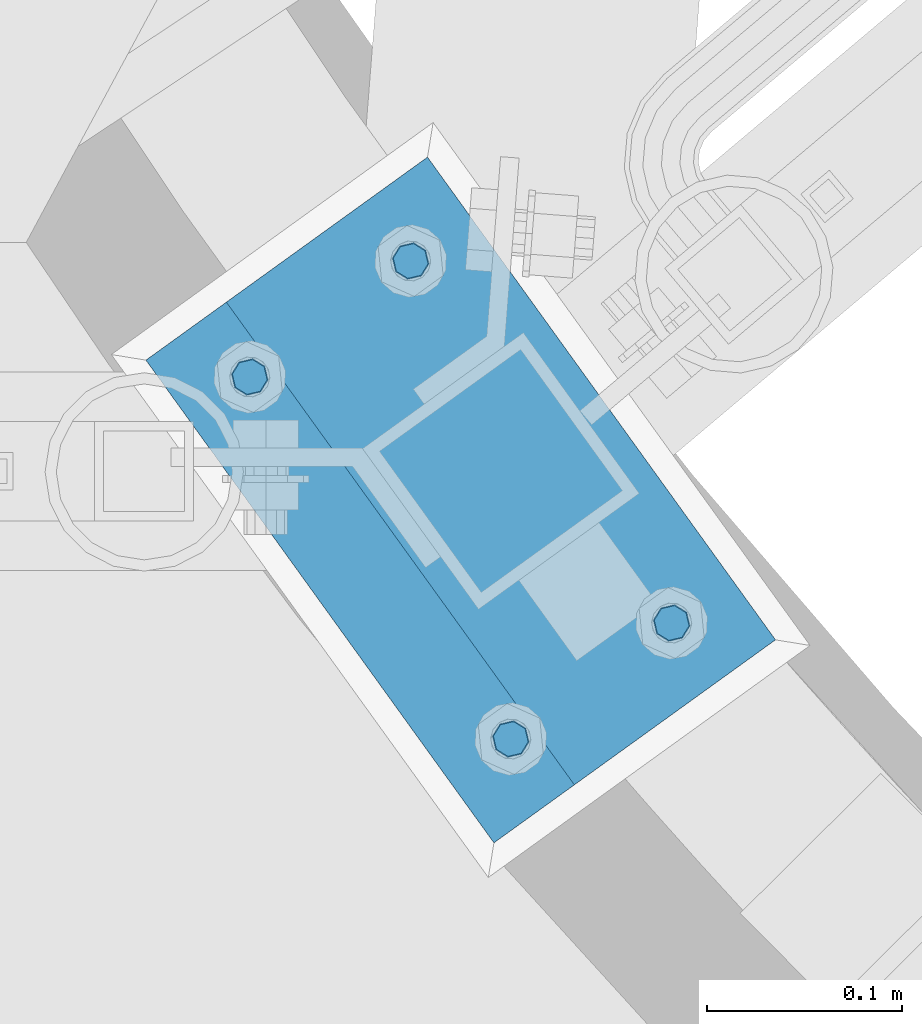
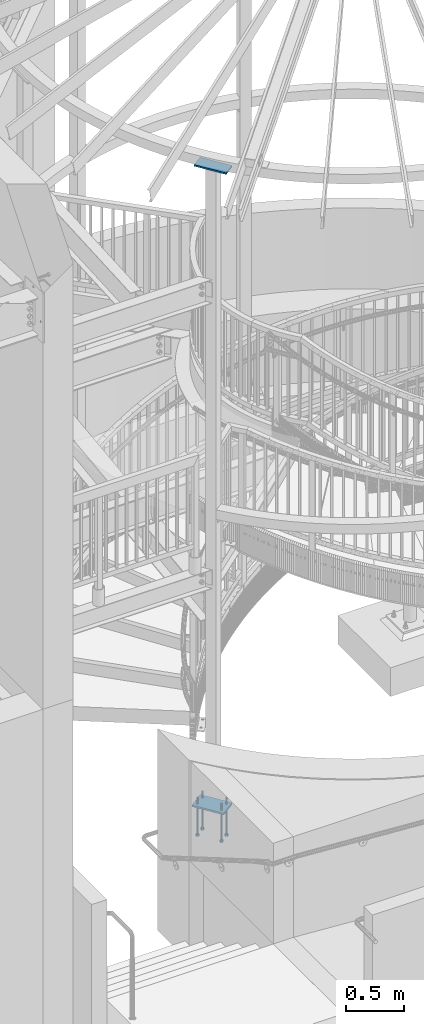
# One storey, part 466 of 975: 7 beams.
"""IFC2X3 building model written with IfcOpenShell, lengths in millimetres."""

from ifc_helpers import new_model, si_unit, frame, origin_with_axes, place, context, subcontext, project, spatial, faceted_brep, material, type_object, element, save


model = new_model("IFC2X3")

# Units and contexts
model_context = context("Model", 3, precision=1e-05, world=origin_with_axes())
body_context = subcontext(model_context, "Body", "Model", "MODEL_VIEW")
ifc_project = project(units=[si_unit("LENGTHUNIT", "METRE", prefix="MILLI"), si_unit("AREAUNIT", "SQUARE_METRE"), si_unit("VOLUMEUNIT", "CUBIC_METRE"), si_unit("MASSUNIT", "GRAM", prefix="KILO"), si_unit("TIMEUNIT", "SECOND"), si_unit("PLANEANGLEUNIT", "RADIAN"), si_unit("SOLIDANGLEUNIT", "STERADIAN"), si_unit("THERMODYNAMICTEMPERATUREUNIT", "DEGREE_CELSIUS"), si_unit("LUMINOUSINTENSITYUNIT", "LUMEN")], contexts=[model_context])

# Site, building, storey
site_placement = place(None, origin_with_axes())
site = spatial("IfcSite", under=ifc_project, at=site_placement, CompositionType="ELEMENT")
building_placement = place(site_placement, origin_with_axes())
building = spatial("IfcBuilding", under=site, at=building_placement, Name="Undefined", CompositionType="ELEMENT")
storey_placement = place(building_placement, origin_with_axes())
storey = spatial("IfcBuildingStorey", under=building, at=storey_placement, Name="Undefined", CompositionType="ELEMENT", Elevation=0.0)

# Beams
ifc_material_1 = material(Name="STEEL/A36")
beam_type_1 = type_object("IfcBeamType", PredefinedType="NOTDEFINED")
beam_1_placement = place(storey_placement, frame((32239.394978559, 1241.42612936098, 8170.86249705359), z_axis=(0.811165211384543, 0.584817065277228, 0.0), x_axis=(-0.584817058957379, 0.811165215940897, 0.0)))
element("IfcBeam", 1, at=beam_1_placement, inside=storey, type_object=beam_type_1, material=ifc_material_1, Name="PLATE", context=body_context, shape_type="Brep", body=[
    faceted_brep([(0.0, 7.9375, -63.5), (0.0, 7.9375, 63.5), (304.799999999529, 7.9375, 63.5), (304.799999999529, 7.9375, -63.5), (0.0, -7.9375, 63.5), (304.799999999529, -7.9375, 63.5), (0.0, -7.9375, -63.5), (304.799999999529, -7.9375, -63.5)], [[[0, 1, 2, 3]], [[1, 4, 5, 2]], [[4, 6, 7, 5]], [[6, 0, 3, 7]], [[5, 7, 3, 2]], [[6, 4, 1, 0]]]),
])
ifc_material_2 = material(Name="STEEL/F1554-36")
beam_type_2 = type_object("IfcBeamType", PredefinedType="NOTDEFINED")
beam_2_placement = place(storey_placement, frame((32021.6134781423, 1413.20083086344, 1371.59999705359), z_axis=(0.584817065277228, -0.811165211384543, 0.0), x_axis=(0.0, 0.0, -1.0)))
element("IfcBeam", 2, at=beam_2_placement, inside=storey, type_object=beam_type_2, material=ifc_material_2, Name="HEADED_ANCHOR_BOLT", context=body_context, shape_type="Brep", body=[
    faceted_brep([(260.34375, -9.13000011445183, 15.8100004195221), (260.34375, -18.2600002289691, -1.45519152283669e-11), (279.393749999999, -18.2600002289691, -1.45519152283669e-11), (279.393749999999, -9.13000011445183, 15.8100004195221), (260.34375, 9.13000011451732, 15.8100004195403), (279.393749999999, 9.13000011451732, 15.8100004195403), (260.34375, 18.2600002289728, 1.81898940354586e-11), (279.393749999999, 18.2600002289728, 1.81898940354586e-11), (260.34375, 9.13000011445547, -15.8100004195221), (279.393749999999, 9.13000011445547, -15.8100004195221), (260.34375, -9.13000011451732, -15.8100004195367), (279.393749999999, -9.13000011451732, -15.8100004195367), (260.34375, -4.47768005528269, 9.29799844174704), (260.34375, -8.06850066050174, 6.43441456486471), (260.34375, -10.0612557562381, 2.29641597050068), (260.34375, -10.0612557562454, -2.29641597051523), (260.34375, -8.06850066052721, -6.43441456487926), (260.34375, -4.47768005531907, -9.29799844175068), (260.34375, -1.81898940354586e-11, -10.319999694766), (260.34375, 4.47768005528633, -9.2979984417434), (260.34375, 8.06850066050174, -6.43441456486471), (260.34375, 10.0612557562381, -2.29641597050068), (260.34375, 10.0612557562454, 2.29641597051886), (260.34375, 8.06850066052357, 6.4344145648829), (260.34375, 4.47768005532271, 9.29799844175432), (260.34375, 2.18278728425503e-11, 10.3199996947696), (279.393749999999, 2.18278728425503e-11, 10.3199996947696), (279.393749999999, -4.47768005528269, 9.29799844174704), (279.393749999999, -8.06850066050174, 6.43441456486471), (279.393749999999, -10.0612557562381, 2.29641597050068), (279.393749999999, -10.0612557562454, -2.29641597051523), (279.393749999999, -8.06850066052721, -6.43441456487926), (279.393749999999, -4.47768005531907, -9.29799844175068), (279.393749999999, -1.81898940354586e-11, -10.319999694766), (279.393749999999, 4.47768005528633, -9.2979984417434), (279.393749999999, 8.06850066050174, -6.43441456486471), (279.393749999999, 10.0612557562381, -2.29641597050068), (279.393749999999, 10.0612557562454, 2.29641597051886), (279.393749999999, 8.06850066052357, 6.4344145648829), (279.393749999999, 4.47768005532271, 9.29799844175432), (0.0, -6.73519209080223, 6.73519209080186), (0.0, -9.52499999999964, 0.0), (279.400000000001, -9.52499999999782, -3.63797880709171e-12), (279.400000000001, -6.73519209079313, 6.73519209079313), (-9.87109982941227e-13, -1.20792265079217e-13, 9.52499961853027), (279.400000000001, 1.09139364212751e-11, 9.52499999999054), (0.0, 6.73519209080223, 6.73519209080186), (279.400000000001, 6.73519209081132, 6.73519209079677), (0.0, 9.52499999999964, 0.0), (279.400000000001, 9.52500000000146, 3.63797880709171e-12), (0.0, 6.73519209080223, -6.73519209080186), (279.400000000001, 6.73519209079677, -6.73519209079313), (2.95075507493764e-12, -1.20792265079217e-13, -9.52499961853027), (279.400000000001, -1.09139364212751e-11, -9.5249999999869), (-126.99791499542, -6.36396103070001, 6.3639610306418), (-126.99791499542, 1.81898940354586e-11, 8.99999999995271), (-126.99791499542, 6.36396103072184, 6.36396103065272), (-126.99791499542, 9.00000000004366, 1.09139364212751e-11), (-126.99791499542, 6.36396103069637, -6.3639610306418), (-126.99791499542, -1.81898940354586e-11, -8.99999999995271), (-126.99791499542, -6.36396103072184, -6.36396103064908), (-126.99791499542, -9.00000000004002, -7.27595761418343e-12), (0.0149743263646087, 6.36396103067818, -6.36396103067909), (0.0149743263646087, 0.0, -9.0), (0.0149743263646087, -6.36396103067818, -6.36396103067909), (0.0149743263987148, -8.9999995411581, -1.00796984270346e-06), (0.0149743263646087, -6.36396103067818, 6.36396103067909), (0.0149743263646087, 0.0, 9.0), (0.0149743263646087, 6.36396103067818, 6.36396103067909), (0.0149743263987148, 9.0000004588419, -1.00796984270346e-06), (0.0, -6.73519209080223, -6.73519209080186), (279.400000000001, -6.73519209080769, -6.73519209079677)], [[[0, 1, 2, 3]], [[4, 0, 3, 5]], [[6, 4, 5, 7]], [[8, 6, 7, 9]], [[10, 8, 9, 11]], [[0, 4, 6, 8, 10, 1], [12, 13, 14, 15, 16, 17, 18, 19, 20, 21, 22, 23, 24, 25]], [[12, 25, 26, 27]], [[13, 12, 27, 28]], [[14, 13, 28, 29]], [[15, 14, 29, 30]], [[16, 15, 30, 31]], [[17, 16, 31, 32]], [[18, 17, 32, 33]], [[19, 18, 33, 34]], [[20, 19, 34, 35]], [[21, 20, 35, 36]], [[22, 21, 36, 37]], [[23, 22, 37, 38]], [[24, 23, 38, 39]], [[25, 24, 39, 26]], [[9, 7, 5, 3, 2, 11], [38, 37, 36, 35, 34, 33, 32, 31, 30, 29, 28, 27, 26, 39]], [[1, 10, 11, 2]], [[40, 41, 42, 43]], [[44, 40, 43, 45]], [[46, 44, 45, 47]], [[48, 46, 47, 49]], [[50, 48, 49, 51]], [[52, 50, 51, 53]], [[54, 55, 56, 57, 58, 59, 60, 61]], [[59, 58, 62, 63]], [[60, 59, 63, 64]], [[61, 60, 64, 65]], [[54, 61, 65, 66]], [[55, 54, 66, 67]], [[56, 55, 67, 68]], [[57, 56, 68, 69]], [[58, 57, 69, 62]], [[40, 44, 46, 48, 50, 52, 70, 41], [68, 67, 66, 65, 64, 63, 62, 69]], [[41, 70, 71, 42]], [[53, 51, 49, 47, 45, 43, 42, 71]], [[70, 52, 53, 71]]]),
])
beam_3_placement = place(storey_placement, frame((32104.0278600483, 1472.6182496472, 1371.59999705359), z_axis=(-0.584817058957379, 0.811165215940897, 0.0), x_axis=(0.0, 0.0, -1.0)))
element("IfcBeam", 3, at=beam_3_placement, inside=storey, type_object=beam_type_2, material=ifc_material_2, Name="HEADED_ANCHOR_BOLT", context=body_context, shape_type="Brep", body=[
    faceted_brep([(260.34375, -9.13000011445183, 15.8100004195221), (260.34375, -18.2600002289691, -1.45519152283669e-11), (279.393749999999, -18.2600002289691, -1.45519152283669e-11), (279.393749999999, -9.13000011445183, 15.8100004195221), (260.34375, 9.13000011451732, 15.8100004195403), (279.393749999999, 9.13000011451732, 15.8100004195403), (260.34375, 18.2600002289728, 1.81898940354586e-11), (279.393749999999, 18.2600002289728, 1.81898940354586e-11), (260.34375, 9.13000011445547, -15.8100004195221), (279.393749999999, 9.13000011445547, -15.8100004195221), (260.34375, -9.13000011451732, -15.8100004195367), (279.393749999999, -9.13000011451732, -15.8100004195367), (260.34375, -4.47768005528269, 9.29799844174704), (260.34375, -8.06850066050174, 6.43441456486471), (260.34375, -10.0612557562381, 2.29641597050068), (260.34375, -10.0612557562454, -2.29641597051523), (260.34375, -8.06850066052721, -6.43441456487926), (260.34375, -4.47768005531907, -9.29799844175068), (260.34375, -1.81898940354586e-11, -10.319999694766), (260.34375, 4.47768005528633, -9.2979984417434), (260.34375, 8.06850066050174, -6.43441456486471), (260.34375, 10.0612557562381, -2.29641597050068), (260.34375, 10.0612557562454, 2.29641597051886), (260.34375, 8.06850066052357, 6.4344145648829), (260.34375, 4.47768005532271, 9.29799844175432), (260.34375, 2.18278728425503e-11, 10.3199996947696), (279.393749999999, 2.18278728425503e-11, 10.3199996947696), (279.393749999999, -4.47768005528269, 9.29799844174704), (279.393749999999, -8.06850066050174, 6.43441456486471), (279.393749999999, -10.0612557562381, 2.29641597050068), (279.393749999999, -10.0612557562454, -2.29641597051523), (279.393749999999, -8.06850066052721, -6.43441456487926), (279.393749999999, -4.47768005531907, -9.29799844175068), (279.393749999999, -1.81898940354586e-11, -10.319999694766), (279.393749999999, 4.47768005528633, -9.2979984417434), (279.393749999999, 8.06850066050174, -6.43441456486471), (279.393749999999, 10.0612557562381, -2.29641597050068), (279.393749999999, 10.0612557562454, 2.29641597051886), (279.393749999999, 8.06850066052357, 6.4344145648829), (279.393749999999, 4.47768005532271, 9.29799844175432), (0.0, -6.73519209080223, 6.73519209080186), (0.0, -9.52499999999964, 0.0), (279.400000000001, -9.52499999999782, -3.63797880709171e-12), (279.400000000001, -6.73519209079313, 6.73519209079313), (-9.87109982941227e-13, -1.20792265079217e-13, 9.52499961853027), (279.400000000001, 1.09139364212751e-11, 9.52499999999054), (0.0, 6.73519209080223, 6.73519209080186), (279.400000000001, 6.73519209081132, 6.73519209079677), (0.0, 9.52499999999964, 0.0), (279.400000000001, 9.52500000000146, 3.63797880709171e-12), (0.0, 6.73519209080223, -6.73519209080186), (279.400000000001, 6.73519209079677, -6.73519209079313), (2.95075507493764e-12, -1.20792265079217e-13, -9.52499961853027), (279.400000000001, -1.09139364212751e-11, -9.5249999999869), (-126.99791499542, -6.36396103070001, 6.3639610306418), (-126.99791499542, 1.81898940354586e-11, 8.99999999995271), (-126.99791499542, 6.36396103072184, 6.36396103065272), (-126.99791499542, 9.00000000004366, 1.09139364212751e-11), (-126.99791499542, 6.36396103069637, -6.3639610306418), (-126.99791499542, -1.81898940354586e-11, -8.99999999995271), (-126.99791499542, -6.36396103072184, -6.36396103064908), (-126.99791499542, -9.00000000004002, -7.27595761418343e-12), (0.0149743263646087, 6.36396103067818, -6.36396103067909), (0.0149743263646087, 0.0, -9.0), (0.0149743263646087, -6.36396103067818, -6.36396103067909), (0.0149743263987148, -8.9999995411581, -1.00796984270346e-06), (0.0149743263646087, -6.36396103067818, 6.36396103067909), (0.0149743263646087, 0.0, 9.0), (0.0149743263646087, 6.36396103067818, 6.36396103067909), (0.0149743263987148, 9.0000004588419, -1.00796984270346e-06), (0.0, -6.73519209080223, -6.73519209080186), (279.400000000001, -6.73519209080769, -6.73519209079677)], [[[0, 1, 2, 3]], [[4, 0, 3, 5]], [[6, 4, 5, 7]], [[8, 6, 7, 9]], [[10, 8, 9, 11]], [[0, 4, 6, 8, 10, 1], [12, 13, 14, 15, 16, 17, 18, 19, 20, 21, 22, 23, 24, 25]], [[12, 25, 26, 27]], [[13, 12, 27, 28]], [[14, 13, 28, 29]], [[15, 14, 29, 30]], [[16, 15, 30, 31]], [[17, 16, 31, 32]], [[18, 17, 32, 33]], [[19, 18, 33, 34]], [[20, 19, 34, 35]], [[21, 20, 35, 36]], [[22, 21, 36, 37]], [[23, 22, 37, 38]], [[24, 23, 38, 39]], [[25, 24, 39, 26]], [[9, 7, 5, 3, 2, 11], [38, 37, 36, 35, 34, 33, 32, 31, 30, 29, 28, 27, 26, 39]], [[1, 10, 11, 2]], [[40, 41, 42, 43]], [[44, 40, 43, 45]], [[46, 44, 45, 47]], [[48, 46, 47, 49]], [[50, 48, 49, 51]], [[52, 50, 51, 53]], [[54, 55, 56, 57, 58, 59, 60, 61]], [[59, 58, 62, 63]], [[60, 59, 63, 64]], [[61, 60, 64, 65]], [[54, 61, 65, 66]], [[55, 54, 66, 67]], [[56, 55, 67, 68]], [[57, 56, 68, 69]], [[58, 57, 69, 62]], [[40, 44, 46, 48, 50, 52, 70, 41], [68, 67, 66, 65, 64, 63, 62, 69]], [[41, 70, 71, 42]], [[53, 51, 49, 47, 45, 43, 42, 71]], [[70, 52, 53, 71]]]),
])
beam_4_placement = place(storey_placement, frame((32237.717041171, 1287.18588232324, 1371.59999705359), z_axis=(-0.584817058957379, 0.811165215940897, 0.0), x_axis=(0.0, 0.0, -1.0)))
element("IfcBeam", 4, at=beam_4_placement, inside=storey, type_object=beam_type_2, material=ifc_material_2, Name="HEADED_ANCHOR_BOLT", context=body_context, shape_type="Brep", body=[
    faceted_brep([(260.34375, -9.13000011445183, 15.8100004195221), (260.34375, -18.2600002289691, -1.45519152283669e-11), (279.393749999999, -18.2600002289691, -1.45519152283669e-11), (279.393749999999, -9.13000011445183, 15.8100004195221), (260.34375, 9.13000011451732, 15.8100004195403), (279.393749999999, 9.13000011451732, 15.8100004195403), (260.34375, 18.2600002289728, 1.81898940354586e-11), (279.393749999999, 18.2600002289728, 1.81898940354586e-11), (260.34375, 9.13000011445547, -15.8100004195221), (279.393749999999, 9.13000011445547, -15.8100004195221), (260.34375, -9.13000011451732, -15.8100004195367), (279.393749999999, -9.13000011451732, -15.8100004195367), (260.34375, -4.47768005528269, 9.29799844174704), (260.34375, -8.06850066050174, 6.43441456486471), (260.34375, -10.0612557562381, 2.29641597050068), (260.34375, -10.0612557562454, -2.29641597051523), (260.34375, -8.06850066052721, -6.43441456487926), (260.34375, -4.47768005531907, -9.29799844175068), (260.34375, -1.81898940354586e-11, -10.319999694766), (260.34375, 4.47768005528633, -9.2979984417434), (260.34375, 8.06850066050174, -6.43441456486471), (260.34375, 10.0612557562381, -2.29641597050068), (260.34375, 10.0612557562454, 2.29641597051886), (260.34375, 8.06850066052357, 6.4344145648829), (260.34375, 4.47768005532271, 9.29799844175432), (260.34375, 2.18278728425503e-11, 10.3199996947696), (279.393749999999, 2.18278728425503e-11, 10.3199996947696), (279.393749999999, -4.47768005528269, 9.29799844174704), (279.393749999999, -8.06850066050174, 6.43441456486471), (279.393749999999, -10.0612557562381, 2.29641597050068), (279.393749999999, -10.0612557562454, -2.29641597051523), (279.393749999999, -8.06850066052721, -6.43441456487926), (279.393749999999, -4.47768005531907, -9.29799844175068), (279.393749999999, -1.81898940354586e-11, -10.319999694766), (279.393749999999, 4.47768005528633, -9.2979984417434), (279.393749999999, 8.06850066050174, -6.43441456486471), (279.393749999999, 10.0612557562381, -2.29641597050068), (279.393749999999, 10.0612557562454, 2.29641597051886), (279.393749999999, 8.06850066052357, 6.4344145648829), (279.393749999999, 4.47768005532271, 9.29799844175432), (0.0, -6.73519209080223, 6.73519209080186), (0.0, -9.52499999999964, 0.0), (279.400000000001, -9.52499999999782, -3.63797880709171e-12), (279.400000000001, -6.73519209079313, 6.73519209079313), (-9.87109982941227e-13, -1.20792265079217e-13, 9.52499961853027), (279.400000000001, 1.09139364212751e-11, 9.52499999999054), (0.0, 6.73519209080223, 6.73519209080186), (279.400000000001, 6.73519209081132, 6.73519209079677), (0.0, 9.52499999999964, 0.0), (279.400000000001, 9.52500000000146, 3.63797880709171e-12), (0.0, 6.73519209080223, -6.73519209080186), (279.400000000001, 6.73519209079677, -6.73519209079313), (2.95075507493764e-12, -1.20792265079217e-13, -9.52499961853027), (279.400000000001, -1.09139364212751e-11, -9.5249999999869), (-126.99791499542, -6.36396103070001, 6.3639610306418), (-126.99791499542, 1.81898940354586e-11, 8.99999999995271), (-126.99791499542, 6.36396103072184, 6.36396103065272), (-126.99791499542, 9.00000000004366, 1.09139364212751e-11), (-126.99791499542, 6.36396103069637, -6.3639610306418), (-126.99791499542, -1.81898940354586e-11, -8.99999999995271), (-126.99791499542, -6.36396103072184, -6.36396103064908), (-126.99791499542, -9.00000000004002, -7.27595761418343e-12), (0.0149743263646087, 6.36396103067818, -6.36396103067909), (0.0149743263646087, 0.0, -9.0), (0.0149743263646087, -6.36396103067818, -6.36396103067909), (0.0149743263987148, -8.9999995411581, -1.00796984270346e-06), (0.0149743263646087, -6.36396103067818, 6.36396103067909), (0.0149743263646087, 0.0, 9.0), (0.0149743263646087, 6.36396103067818, 6.36396103067909), (0.0149743263987148, 9.0000004588419, -1.00796984270346e-06), (0.0, -6.73519209080223, -6.73519209080186), (279.400000000001, -6.73519209080769, -6.73519209079677)], [[[0, 1, 2, 3]], [[4, 0, 3, 5]], [[6, 4, 5, 7]], [[8, 6, 7, 9]], [[10, 8, 9, 11]], [[0, 4, 6, 8, 10, 1], [12, 13, 14, 15, 16, 17, 18, 19, 20, 21, 22, 23, 24, 25]], [[12, 25, 26, 27]], [[13, 12, 27, 28]], [[14, 13, 28, 29]], [[15, 14, 29, 30]], [[16, 15, 30, 31]], [[17, 16, 31, 32]], [[18, 17, 32, 33]], [[19, 18, 33, 34]], [[20, 19, 34, 35]], [[21, 20, 35, 36]], [[22, 21, 36, 37]], [[23, 22, 37, 38]], [[24, 23, 38, 39]], [[25, 24, 39, 26]], [[9, 7, 5, 3, 2, 11], [38, 37, 36, 35, 34, 33, 32, 31, 30, 29, 28, 27, 26, 39]], [[1, 10, 11, 2]], [[40, 41, 42, 43]], [[44, 40, 43, 45]], [[46, 44, 45, 47]], [[48, 46, 47, 49]], [[50, 48, 49, 51]], [[52, 50, 51, 53]], [[54, 55, 56, 57, 58, 59, 60, 61]], [[59, 58, 62, 63]], [[60, 59, 63, 64]], [[61, 60, 64, 65]], [[54, 61, 65, 66]], [[55, 54, 66, 67]], [[56, 55, 67, 68]], [[57, 56, 68, 69]], [[58, 57, 69, 62]], [[40, 44, 46, 48, 50, 52, 70, 41], [68, 67, 66, 65, 64, 63, 62, 69]], [[41, 70, 71, 42]], [[53, 51, 49, 47, 45, 43, 42, 71]], [[70, 52, 53, 71]]]),
])
beam_5_placement = place(storey_placement, frame((32155.302659264, 1227.76846354077, 1371.59999705359), z_axis=(0.584817065277228, -0.811165211384543, 0.0), x_axis=(0.0, 0.0, -1.0)))
element("IfcBeam", 5, at=beam_5_placement, inside=storey, type_object=beam_type_2, material=ifc_material_2, Name="HEADED_ANCHOR_BOLT", context=body_context, shape_type="Brep", body=[
    faceted_brep([(260.34375, -9.13000011445183, 15.8100004195221), (260.34375, -18.2600002289691, -1.45519152283669e-11), (279.393749999999, -18.2600002289691, -1.45519152283669e-11), (279.393749999999, -9.13000011445183, 15.8100004195221), (260.34375, 9.13000011451732, 15.8100004195403), (279.393749999999, 9.13000011451732, 15.8100004195403), (260.34375, 18.2600002289728, 1.81898940354586e-11), (279.393749999999, 18.2600002289728, 1.81898940354586e-11), (260.34375, 9.13000011445547, -15.8100004195221), (279.393749999999, 9.13000011445547, -15.8100004195221), (260.34375, -9.13000011451732, -15.8100004195367), (279.393749999999, -9.13000011451732, -15.8100004195367), (260.34375, -4.47768005528269, 9.29799844174704), (260.34375, -8.06850066050174, 6.43441456486471), (260.34375, -10.0612557562381, 2.29641597050068), (260.34375, -10.0612557562454, -2.29641597051523), (260.34375, -8.06850066052721, -6.43441456487926), (260.34375, -4.47768005531907, -9.29799844175068), (260.34375, -1.81898940354586e-11, -10.319999694766), (260.34375, 4.47768005528633, -9.2979984417434), (260.34375, 8.06850066050174, -6.43441456486471), (260.34375, 10.0612557562381, -2.29641597050068), (260.34375, 10.0612557562454, 2.29641597051886), (260.34375, 8.06850066052357, 6.4344145648829), (260.34375, 4.47768005532271, 9.29799844175432), (260.34375, 2.18278728425503e-11, 10.3199996947696), (279.393749999999, 2.18278728425503e-11, 10.3199996947696), (279.393749999999, -4.47768005528269, 9.29799844174704), (279.393749999999, -8.06850066050174, 6.43441456486471), (279.393749999999, -10.0612557562381, 2.29641597050068), (279.393749999999, -10.0612557562454, -2.29641597051523), (279.393749999999, -8.06850066052721, -6.43441456487926), (279.393749999999, -4.47768005531907, -9.29799844175068), (279.393749999999, -1.81898940354586e-11, -10.319999694766), (279.393749999999, 4.47768005528633, -9.2979984417434), (279.393749999999, 8.06850066050174, -6.43441456486471), (279.393749999999, 10.0612557562381, -2.29641597050068), (279.393749999999, 10.0612557562454, 2.29641597051886), (279.393749999999, 8.06850066052357, 6.4344145648829), (279.393749999999, 4.47768005532271, 9.29799844175432), (0.0, -6.73519209080223, 6.73519209080186), (0.0, -9.52499999999964, 0.0), (279.400000000001, -9.52499999999782, -3.63797880709171e-12), (279.400000000001, -6.73519209079313, 6.73519209079313), (-9.87109982941227e-13, -1.20792265079217e-13, 9.52499961853027), (279.400000000001, 1.09139364212751e-11, 9.52499999999054), (0.0, 6.73519209080223, 6.73519209080186), (279.400000000001, 6.73519209081132, 6.73519209079677), (0.0, 9.52499999999964, 0.0), (279.400000000001, 9.52500000000146, 3.63797880709171e-12), (0.0, 6.73519209080223, -6.73519209080186), (279.400000000001, 6.73519209079677, -6.73519209079313), (2.95075507493764e-12, -1.20792265079217e-13, -9.52499961853027), (279.400000000001, -1.09139364212751e-11, -9.5249999999869), (-126.99791499542, -6.36396103070001, 6.3639610306418), (-126.99791499542, 1.81898940354586e-11, 8.99999999995271), (-126.99791499542, 6.36396103072184, 6.36396103065272), (-126.99791499542, 9.00000000004366, 1.09139364212751e-11), (-126.99791499542, 6.36396103069637, -6.3639610306418), (-126.99791499542, -1.81898940354586e-11, -8.99999999995271), (-126.99791499542, -6.36396103072184, -6.36396103064908), (-126.99791499542, -9.00000000004002, -7.27595761418343e-12), (0.0149743263646087, 6.36396103067818, -6.36396103067909), (0.0149743263646087, 0.0, -9.0), (0.0149743263646087, -6.36396103067818, -6.36396103067909), (0.0149743263987148, -8.9999995411581, -1.00796984270346e-06), (0.0149743263646087, -6.36396103067818, 6.36396103067909), (0.0149743263646087, 0.0, 9.0), (0.0149743263646087, 6.36396103067818, 6.36396103067909), (0.0149743263987148, 9.0000004588419, -1.00796984270346e-06), (0.0, -6.73519209080223, -6.73519209080186), (279.400000000001, -6.73519209080769, -6.73519209079677)], [[[0, 1, 2, 3]], [[4, 0, 3, 5]], [[6, 4, 5, 7]], [[8, 6, 7, 9]], [[10, 8, 9, 11]], [[0, 4, 6, 8, 10, 1], [12, 13, 14, 15, 16, 17, 18, 19, 20, 21, 22, 23, 24, 25]], [[12, 25, 26, 27]], [[13, 12, 27, 28]], [[14, 13, 28, 29]], [[15, 14, 29, 30]], [[16, 15, 30, 31]], [[17, 16, 31, 32]], [[18, 17, 32, 33]], [[19, 18, 33, 34]], [[20, 19, 34, 35]], [[21, 20, 35, 36]], [[22, 21, 36, 37]], [[23, 22, 37, 38]], [[24, 23, 38, 39]], [[25, 24, 39, 26]], [[9, 7, 5, 3, 2, 11], [38, 37, 36, 35, 34, 33, 32, 31, 30, 29, 28, 27, 26, 39]], [[1, 10, 11, 2]], [[40, 41, 42, 43]], [[44, 40, 43, 45]], [[46, 44, 45, 47]], [[48, 46, 47, 49]], [[50, 48, 49, 51]], [[52, 50, 51, 53]], [[54, 55, 56, 57, 58, 59, 60, 61]], [[59, 58, 62, 63]], [[60, 59, 63, 64]], [[61, 60, 64, 65]], [[54, 61, 65, 66]], [[55, 54, 66, 67]], [[56, 55, 67, 68]], [[57, 56, 68, 69]], [[58, 57, 69, 62]], [[40, 44, 46, 48, 50, 52, 70, 41], [68, 67, 66, 65, 64, 63, 62, 69]], [[41, 70, 71, 42]], [[53, 51, 49, 47, 45, 43, 42, 71]], [[70, 52, 53, 71]]]),
])
beam_type_3 = type_object("IfcBeamType", PredefinedType="NOTDEFINED")
beam_6_placement = place(storey_placement, frame((32218.7913821894, 1226.57177590251, 1419.22499705359), z_axis=(-0.811165211384535, -0.58481706527724, 0.0), x_axis=(-0.584817058957379, 0.811165215940897, 0.0)))
element("IfcBeam", 6, at=beam_6_placement, inside=storey, type_object=beam_type_3, material=ifc_material_1, Name="PLATE", context=body_context, shape_type="Brep", body=[
    faceted_brep([(0.0, 9.52499999999964, -88.9000000000015), (0.0, 9.52499999999964, 88.9000000000015), (304.800000000429, 9.52500000000009, 88.9000000003653), (304.800000000414, 9.52500000000009, -88.8999999996704), (0.0, -9.52499999999964, 88.9000000000015), (304.800000000429, -9.52500000000009, 88.9000000003653), (0.0, -9.52499999999964, -88.9000000000015), (304.800000000414, -9.52500000000009, -88.8999999996704)], [[[0, 1, 2, 3]], [[1, 4, 5, 2]], [[4, 6, 7, 5]], [[6, 0, 3, 7]], [[5, 7, 3, 2]], [[6, 4, 1, 0]]]),
])
beam_type_4 = type_object("IfcBeamType", PredefinedType="NOTDEFINED")
beam_7_placement = place(storey_placement, frame((32218.7913821897, 1226.57177590289, 1411.28749705359), z_axis=(-0.811165211384535, -0.58481706527724, 0.0), x_axis=(-0.584817058957379, 0.811165215940897, 0.0)))
element("IfcBeam", 7, at=beam_7_placement, inside=storey, type_object=beam_type_4, material=ifc_material_1, Name="TEMPLATE", context=body_context, shape_type="Brep", body=[
    faceted_brep([(-1.09139364212751e-11, 1.58750000000009, -88.900000000016), (3.63797880709171e-12, 1.58750000000009, 88.9000000000196), (304.800000000418, 1.58750000000009, 88.9000000003762), (304.800000000399, 1.58750000000009, -88.8999999996631), (3.63797880709171e-12, -1.58750000000009, 88.9000000000196), (304.800000000418, -1.58750000000009, 88.9000000003762), (-1.09139364212751e-11, -1.58750000000009, -88.900000000016), (304.800000000399, -1.58750000000009, -88.8999999996631)], [[[0, 1, 2, 3]], [[1, 4, 5, 2]], [[4, 6, 7, 5]], [[6, 0, 3, 7]], [[5, 7, 3, 2]], [[6, 4, 1, 0]]]),
])

save(model, "model.ifc")
